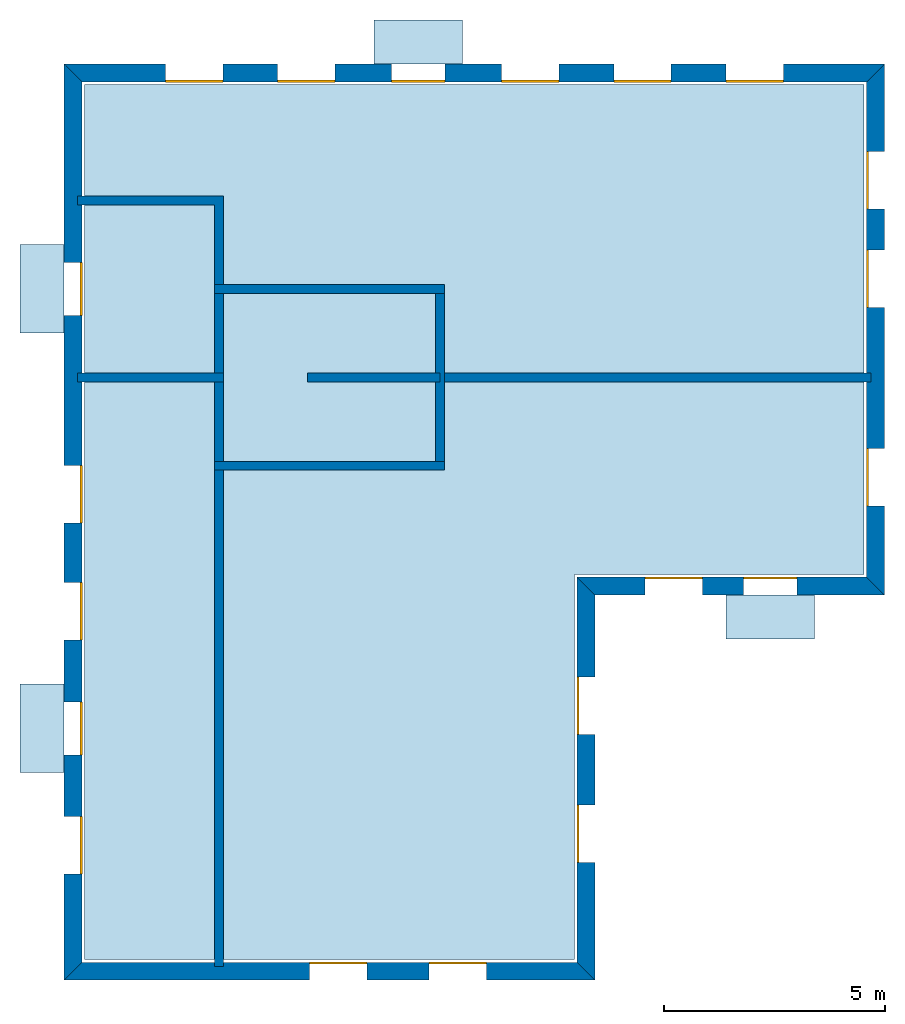
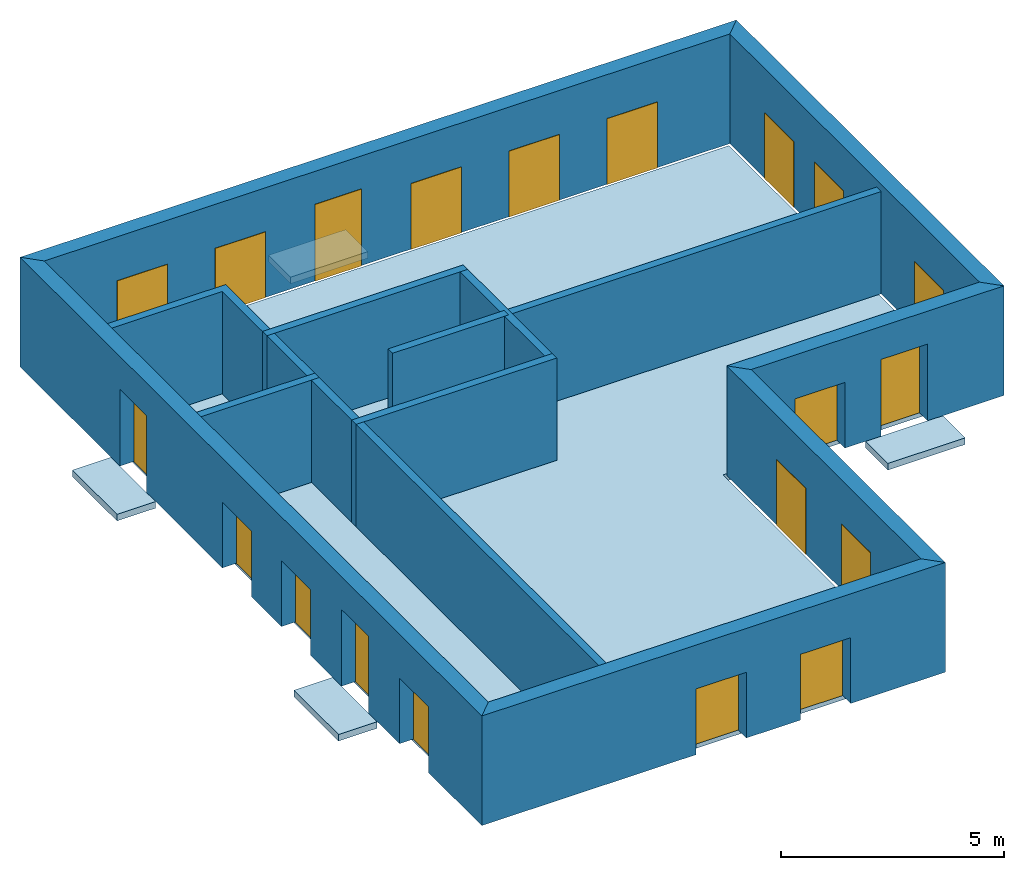
# One storey: 20 windows, 15 walls, 5 slabs, 20 openings.
"""IFC4 building model written with IfcOpenShell, lengths in metres."""

from ifc_helpers import new_model, si_unit, frame, origin_with_axes, place, context, subcontext, project, spatial, line, indexed_curve, outline, extrude, element, fill, save


model = new_model("IFC4")

# Units and contexts
model_context = context("Model", 3, precision=1e-05, world=origin_with_axes())
body_context = subcontext(model_context, "Body", "Model", "MODEL_VIEW")
ifc_project = project(units=[si_unit("AREAUNIT", "SQUARE_METRE"), si_unit("VOLUMEUNIT", "CUBIC_METRE"), si_unit("LENGTHUNIT", "METRE")], contexts=[model_context])

# Site, building, storey
site = spatial("IfcSite", under=ifc_project)
building = spatial("IfcBuilding", under=site, Name="Building 1")
storey_placement = place(None, frame((0.0, 0.0, 4.0), z_axis=(0.0, 0.0, 1.0), x_axis=(1.0, 0.0, 0.0)))
storey = spatial("IfcBuildingStorey", under=building, at=storey_placement, Name="02 Storey")

# Slabs
slab_1_placement = place(storey_placement, origin_with_axes())
element("IfcSlab", 1, at=slab_1_placement, inside=storey, Name="Slab", context=body_context, shape_type="SweptSolid", body=[
    extrude(outline(indexed_curve([(15.533354, 14.715575), (22.079464, 14.715575), (22.079464, 25.795575), (4.453354, 25.795575), (4.453354, 6.0082), (15.533354, 6.0082)], segments=[line(1, 2), line(2, 3), line(3, 4), line(4, 5), line(5, 6)])), origin_with_axes(), (0.0, 0.0, -1.0), 0.2),
])
slab_2_placement = place(storey_placement, origin_with_axes())
element("IfcSlab", 2, at=slab_2_placement, inside=storey, Name="Balcony", context=body_context, shape_type="SweptSolid", body=[
    extrude(outline(indexed_curve([(20.9574273333333, 14.255575), (20.9574273333333, 13.255575), (18.9574273333333, 13.255575), (18.9574273333333, 14.255575)], segments=[line(1, 2), line(2, 3), line(3, 4)])), origin_with_axes(), (0.0, 0.0, -1.0), 0.18),
])
slab_3_placement = place(storey_placement, origin_with_axes())
element("IfcSlab", 3, at=slab_3_placement, inside=storey, Name="Balcony", context=body_context, shape_type="SweptSolid", body=[
    extrude(outline(indexed_curve([(10.9988297142857, 26.255575), (10.9988297142857, 27.255575), (12.9988297142857, 27.255575), (12.9988297142857, 26.255575)], segments=[line(1, 2), line(2, 3), line(3, 4)])), origin_with_axes(), (0.0, 0.0, -1.0), 0.18),
])
slab_4_placement = place(storey_placement, origin_with_axes())
element("IfcSlab", 4, at=slab_4_placement, inside=storey, Name="Balcony", context=body_context, shape_type="SweptSolid", body=[
    extrude(outline(indexed_curve([(3.993354, 10.2388972), (2.993354, 10.2388972), (2.993354, 12.2388972), (3.993354, 12.2388972)], segments=[line(1, 2), line(2, 3), line(3, 4)])), origin_with_axes(), (0.0, 0.0, -1.0), 0.18),
])
slab_5_placement = place(storey_placement, origin_with_axes())
element("IfcSlab", 5, at=slab_5_placement, inside=storey, Name="Balcony", context=body_context, shape_type="SweptSolid", body=[
    extrude(outline(indexed_curve([(3.993354, 20.174943), (2.993354, 20.174943), (2.993354, 22.174943), (3.993354, 22.174943)], segments=[line(1, 2), line(2, 3), line(3, 4)])), origin_with_axes(), (0.0, 0.0, -1.0), 0.18),
])

# Walls
wall_1_placement = place(storey_placement, origin_with_axes())
element("IfcWall", 6, at=wall_1_placement, inside=storey, Name="Wall", context=body_context, shape_type="SweptSolid", body=[
    extrude(outline(indexed_curve([(22.239464, 19.274943), (12.393354, 19.274943), (12.393354, 19.074943), (22.239464, 19.074943)], segments=[line(1, 2), line(2, 3), line(3, 4)])), origin_with_axes(), (0.0, 0.0, 1.0), 2.8),
])
wall_2_placement = place(storey_placement, origin_with_axes())
element("IfcWall", 7, at=wall_2_placement, inside=storey, Name="Wall", context=body_context, shape_type="SweptSolid", body=[
    extrude(outline(indexed_curve([(7.593354, 17.274943), (7.393354, 17.274943), (7.393354, 5.8482), (7.593354, 5.8482)], segments=[line(1, 2), line(2, 3), line(3, 4)])), origin_with_axes(), (0.0, 0.0, 1.0), 2.8),
])
wall_3_placement = place(storey_placement, origin_with_axes())
element("IfcWall", 8, at=wall_3_placement, inside=storey, Name="Wall", context=body_context, shape_type="SweptSolid", body=[
    extrude(outline(indexed_curve([(7.593354, 19.274943), (4.293354, 19.274943), (4.293354, 19.074943), (7.593354, 19.074943)], segments=[line(1, 2), line(2, 3), line(3, 4)])), origin_with_axes(), (0.0, 0.0, 1.0), 2.8),
])
wall_4_placement = place(storey_placement, origin_with_axes())
element("IfcWall", 9, at=wall_4_placement, inside=storey, Name="Wall", context=body_context, shape_type="SweptSolid", body=[
    extrude(outline(indexed_curve([(7.593354, 23.274943), (4.293354, 23.274943), (4.293354, 23.074943), (7.393354, 23.074943), (7.393354, 21.074943), (7.593354, 21.074943)], segments=[line(1, 2), line(2, 3), line(3, 4), line(4, 5), line(5, 6)])), origin_with_axes(), (0.0, 0.0, 1.0), 2.8),
])

# Wall, openings, windows
wall_5_placement = place(storey_placement, origin_with_axes())
wall_5 = element("IfcWall", 10, at=wall_5_placement, inside=storey, Name="Facade", context=body_context, shape_type="SweptSolid", body=[
    extrude(outline(indexed_curve([(15.593354, 14.655575), (22.139464, 14.655575), (22.539464, 14.255575), (15.993354, 14.255575)], segments=[line(1, 2), line(2, 3), line(3, 4)])), origin_with_axes(), (0.0, 0.0, 1.0), 3.0),
])
opening_1_placement = place(wall_5_placement, origin_with_axes())
opening_1 = element("IfcOpeningElement", 11, at=opening_1_placement, cuts=wall_5, Name="Opening", context=body_context, shape_type="SweptSolid", body=[
    extrude(outline(indexed_curve([(17.1253906666667, 14.215575), (17.1253906666667, 14.715575), (18.4253906666667, 14.715575), (18.4253906666667, 14.215575)], segments=[line(1, 2), line(2, 3), line(3, 4)])), origin_with_axes(), (0.0, 0.0, 1.0), 1.8),
])
opening_2_placement = place(wall_5_placement, origin_with_axes())
opening_2 = element("IfcOpeningElement", 12, at=opening_2_placement, cuts=wall_5, Name="Opening", context=body_context, shape_type="SweptSolid", body=[
    extrude(outline(indexed_curve([(19.3574273333333, 14.215575), (19.3574273333333, 14.715575), (20.5574273333333, 14.715575), (20.5574273333333, 14.215575)], segments=[line(1, 2), line(2, 3), line(3, 4)])), origin_with_axes(), (0.0, 0.0, 1.0), 2.1),
])
window_1_placement = place(storey_placement, origin_with_axes())
window_1 = element("IfcWindow", 13, at=window_1_placement, inside=storey, Name="Window", PredefinedType="WINDOW", context=body_context, shape_type="SweptSolid", body=[
    extrude(outline(indexed_curve([(17.1253906666667, 14.615575), (17.1253906666667, 14.665575), (18.4253906666667, 14.665575), (18.4253906666667, 14.615575)], segments=[line(1, 2), line(2, 3), line(3, 4)])), origin_with_axes(), (0.0, 0.0, 1.0), 1.8),
])
fill(opening_1, window_1)
window_2_placement = place(storey_placement, origin_with_axes())
window_2 = element("IfcWindow", 14, at=window_2_placement, inside=storey, Name="Window", PredefinedType="WINDOW", context=body_context, shape_type="SweptSolid", body=[
    extrude(outline(indexed_curve([(19.3574273333333, 14.615575), (19.3574273333333, 14.665575), (20.5574273333333, 14.665575), (20.5574273333333, 14.615575)], segments=[line(1, 2), line(2, 3), line(3, 4)])), origin_with_axes(), (0.0, 0.0, 1.0), 2.1),
])
fill(opening_2, window_2)

wall_6_placement = place(storey_placement, origin_with_axes())
wall_6 = element("IfcWall", 15, at=wall_6_placement, inside=storey, Name="Facade", context=body_context, shape_type="SweptSolid", body=[
    extrude(outline(indexed_curve([(22.139464, 14.655575), (22.139464, 25.855575), (22.539464, 26.255575), (22.539464, 14.255575)], segments=[line(1, 2), line(2, 3), line(3, 4)])), origin_with_axes(), (0.0, 0.0, 1.0), 3.0),
])
opening_3_placement = place(wall_6_placement, origin_with_axes())
opening_3 = element("IfcOpeningElement", 16, at=opening_3_placement, cuts=wall_6, Name="Opening", context=body_context, shape_type="SweptSolid", body=[
    extrude(outline(indexed_curve([(22.579464, 16.265259), (22.079464, 16.265259), (22.079464, 17.565259), (22.579464, 17.565259)], segments=[line(1, 2), line(2, 3), line(3, 4)])), origin_with_axes(), (0.0, 0.0, 1.0), 1.8),
])
opening_4_placement = place(wall_6_placement, origin_with_axes())
opening_4 = element("IfcOpeningElement", 17, at=opening_4_placement, cuts=wall_6, Name="Opening", context=body_context, shape_type="SweptSolid", body=[
    extrude(outline(indexed_curve([(22.579464, 20.7518203333333), (22.079464, 20.7518203333333), (22.079464, 22.0518203333333), (22.579464, 22.0518203333333)], segments=[line(1, 2), line(2, 3), line(3, 4)])), origin_with_axes(), (0.0, 0.0, 1.0), 1.8),
])
opening_5_placement = place(wall_6_placement, origin_with_axes())
opening_5 = element("IfcOpeningElement", 18, at=opening_5_placement, cuts=wall_6, Name="Opening", context=body_context, shape_type="SweptSolid", body=[
    extrude(outline(indexed_curve([(22.579464, 22.9786976666667), (22.079464, 22.9786976666667), (22.079464, 24.2786976666667), (22.579464, 24.2786976666667)], segments=[line(1, 2), line(2, 3), line(3, 4)])), origin_with_axes(), (0.0, 0.0, 1.0), 1.8),
])
window_3_placement = place(storey_placement, origin_with_axes())
window_3 = element("IfcWindow", 19, at=window_3_placement, inside=storey, Name="Window", PredefinedType="WINDOW", context=body_context, shape_type="SweptSolid", body=[
    extrude(outline(indexed_curve([(22.179464, 16.265259), (22.129464, 16.265259), (22.129464, 17.565259), (22.179464, 17.565259)], segments=[line(1, 2), line(2, 3), line(3, 4)])), origin_with_axes(), (0.0, 0.0, 1.0), 1.8),
])
fill(opening_3, window_3)
window_4_placement = place(storey_placement, origin_with_axes())
window_4 = element("IfcWindow", 20, at=window_4_placement, inside=storey, Name="Window", PredefinedType="WINDOW", context=body_context, shape_type="SweptSolid", body=[
    extrude(outline(indexed_curve([(22.179464, 20.7518203333333), (22.129464, 20.7518203333333), (22.129464, 22.0518203333333), (22.179464, 22.0518203333333)], segments=[line(1, 2), line(2, 3), line(3, 4)])), origin_with_axes(), (0.0, 0.0, 1.0), 1.8),
])
fill(opening_4, window_4)
window_5_placement = place(storey_placement, origin_with_axes())
window_5 = element("IfcWindow", 21, at=window_5_placement, inside=storey, Name="Window", PredefinedType="WINDOW", context=body_context, shape_type="SweptSolid", body=[
    extrude(outline(indexed_curve([(22.179464, 22.9786976666667), (22.129464, 22.9786976666667), (22.129464, 24.2786976666667), (22.179464, 24.2786976666667)], segments=[line(1, 2), line(2, 3), line(3, 4)])), origin_with_axes(), (0.0, 0.0, 1.0), 1.8),
])
fill(opening_5, window_5)

wall_7_placement = place(storey_placement, origin_with_axes())
wall_7 = element("IfcWall", 22, at=wall_7_placement, inside=storey, Name="Facade", context=body_context, shape_type="SweptSolid", body=[
    extrude(outline(indexed_curve([(22.139464, 25.855575), (4.393354, 25.855575), (3.993354, 26.255575), (22.539464, 26.255575)], segments=[line(1, 2), line(2, 3), line(3, 4)])), origin_with_axes(), (0.0, 0.0, 1.0), 3.0),
])
opening_6_placement = place(wall_7_placement, origin_with_axes())
opening_6 = element("IfcOpeningElement", 23, at=opening_6_placement, cuts=wall_7, Name="Opening", context=body_context, shape_type="SweptSolid", body=[
    extrude(outline(indexed_curve([(20.2543054285714, 26.295575), (20.2543054285714, 25.795575), (18.9543054285714, 25.795575), (18.9543054285714, 26.295575)], segments=[line(1, 2), line(2, 3), line(3, 4)])), origin_with_axes(), (0.0, 0.0, 1.0), 1.8),
])
opening_7_placement = place(wall_7_placement, origin_with_axes())
opening_7 = element("IfcOpeningElement", 24, at=opening_7_placement, cuts=wall_7, Name="Opening", context=body_context, shape_type="SweptSolid", body=[
    extrude(outline(indexed_curve([(17.7191468571429, 26.295575), (17.7191468571429, 25.795575), (16.4191468571429, 25.795575), (16.4191468571429, 26.295575)], segments=[line(1, 2), line(2, 3), line(3, 4)])), origin_with_axes(), (0.0, 0.0, 1.0), 1.8),
])
opening_8_placement = place(wall_7_placement, origin_with_axes())
opening_8 = element("IfcOpeningElement", 25, at=opening_8_placement, cuts=wall_7, Name="Opening", context=body_context, shape_type="SweptSolid", body=[
    extrude(outline(indexed_curve([(15.1839882857143, 26.295575), (15.1839882857143, 25.795575), (13.8839882857143, 25.795575), (13.8839882857143, 26.295575)], segments=[line(1, 2), line(2, 3), line(3, 4)])), origin_with_axes(), (0.0, 0.0, 1.0), 1.8),
])
opening_9_placement = place(wall_7_placement, origin_with_axes())
opening_9 = element("IfcOpeningElement", 26, at=opening_9_placement, cuts=wall_7, Name="Opening", context=body_context, shape_type="SweptSolid", body=[
    extrude(outline(indexed_curve([(12.5988297142857, 26.295575), (12.5988297142857, 25.795575), (11.3988297142857, 25.795575), (11.3988297142857, 26.295575)], segments=[line(1, 2), line(2, 3), line(3, 4)])), origin_with_axes(), (0.0, 0.0, 1.0), 2.1),
])
opening_10_placement = place(wall_7_placement, origin_with_axes())
opening_10 = element("IfcOpeningElement", 27, at=opening_10_placement, cuts=wall_7, Name="Opening", context=body_context, shape_type="SweptSolid", body=[
    extrude(outline(indexed_curve([(10.1136711428571, 26.295575), (10.1136711428571, 25.795575), (8.81367114285714, 25.795575), (8.81367114285714, 26.295575)], segments=[line(1, 2), line(2, 3), line(3, 4)])), origin_with_axes(), (0.0, 0.0, 1.0), 1.8),
])
opening_11_placement = place(wall_7_placement, origin_with_axes())
opening_11 = element("IfcOpeningElement", 28, at=opening_11_placement, cuts=wall_7, Name="Opening", context=body_context, shape_type="SweptSolid", body=[
    extrude(outline(indexed_curve([(7.57851257142857, 26.295575), (7.57851257142857, 25.795575), (6.27851257142857, 25.795575), (6.27851257142857, 26.295575)], segments=[line(1, 2), line(2, 3), line(3, 4)])), origin_with_axes(), (0.0, 0.0, 1.0), 1.8),
])
window_6_placement = place(storey_placement, origin_with_axes())
window_6 = element("IfcWindow", 29, at=window_6_placement, inside=storey, Name="Window", PredefinedType="WINDOW", context=body_context, shape_type="SweptSolid", body=[
    extrude(outline(indexed_curve([(20.2543054285714, 25.895575), (20.2543054285714, 25.845575), (18.9543054285714, 25.845575), (18.9543054285714, 25.895575)], segments=[line(1, 2), line(2, 3), line(3, 4)])), origin_with_axes(), (0.0, 0.0, 1.0), 1.8),
])
fill(opening_6, window_6)
window_7_placement = place(storey_placement, origin_with_axes())
window_7 = element("IfcWindow", 30, at=window_7_placement, inside=storey, Name="Window", PredefinedType="WINDOW", context=body_context, shape_type="SweptSolid", body=[
    extrude(outline(indexed_curve([(17.7191468571429, 25.895575), (17.7191468571429, 25.845575), (16.4191468571429, 25.845575), (16.4191468571429, 25.895575)], segments=[line(1, 2), line(2, 3), line(3, 4)])), origin_with_axes(), (0.0, 0.0, 1.0), 1.8),
])
fill(opening_7, window_7)
window_8_placement = place(storey_placement, origin_with_axes())
window_8 = element("IfcWindow", 31, at=window_8_placement, inside=storey, Name="Window", PredefinedType="WINDOW", context=body_context, shape_type="SweptSolid", body=[
    extrude(outline(indexed_curve([(15.1839882857143, 25.895575), (15.1839882857143, 25.845575), (13.8839882857143, 25.845575), (13.8839882857143, 25.895575)], segments=[line(1, 2), line(2, 3), line(3, 4)])), origin_with_axes(), (0.0, 0.0, 1.0), 1.8),
])
fill(opening_8, window_8)
window_9_placement = place(storey_placement, origin_with_axes())
window_9 = element("IfcWindow", 32, at=window_9_placement, inside=storey, Name="Window", PredefinedType="WINDOW", context=body_context, shape_type="SweptSolid", body=[
    extrude(outline(indexed_curve([(12.5988297142857, 25.895575), (12.5988297142857, 25.845575), (11.3988297142857, 25.845575), (11.3988297142857, 25.895575)], segments=[line(1, 2), line(2, 3), line(3, 4)])), origin_with_axes(), (0.0, 0.0, 1.0), 2.1),
])
fill(opening_9, window_9)
window_10_placement = place(storey_placement, origin_with_axes())
window_10 = element("IfcWindow", 33, at=window_10_placement, inside=storey, Name="Window", PredefinedType="WINDOW", context=body_context, shape_type="SweptSolid", body=[
    extrude(outline(indexed_curve([(10.1136711428571, 25.895575), (10.1136711428571, 25.845575), (8.81367114285714, 25.845575), (8.81367114285714, 25.895575)], segments=[line(1, 2), line(2, 3), line(3, 4)])), origin_with_axes(), (0.0, 0.0, 1.0), 1.8),
])
fill(opening_10, window_10)
window_11_placement = place(storey_placement, origin_with_axes())
window_11 = element("IfcWindow", 34, at=window_11_placement, inside=storey, Name="Window", PredefinedType="WINDOW", context=body_context, shape_type="SweptSolid", body=[
    extrude(outline(indexed_curve([(7.57851257142857, 25.895575), (7.57851257142857, 25.845575), (6.27851257142857, 25.845575), (6.27851257142857, 25.895575)], segments=[line(1, 2), line(2, 3), line(3, 4)])), origin_with_axes(), (0.0, 0.0, 1.0), 1.8),
])
fill(opening_11, window_11)

wall_8_placement = place(storey_placement, origin_with_axes())
wall_8 = element("IfcWall", 35, at=wall_8_placement, inside=storey, Name="Facade", context=body_context, shape_type="SweptSolid", body=[
    extrude(outline(indexed_curve([(4.393354, 25.855575), (4.393354, 5.9482), (3.993354, 5.5482), (3.993354, 26.255575)], segments=[line(1, 2), line(2, 3), line(3, 4)])), origin_with_axes(), (0.0, 0.0, 1.0), 3.0),
])
opening_12_placement = place(wall_8_placement, origin_with_axes())
opening_12 = element("IfcOpeningElement", 36, at=opening_12_placement, cuts=wall_8, Name="Opening", context=body_context, shape_type="SweptSolid", body=[
    extrude(outline(indexed_curve([(3.953354, 17.1795944), (4.453354, 17.1795944), (4.453354, 15.8795944), (3.953354, 15.8795944)], segments=[line(1, 2), line(2, 3), line(3, 4)])), origin_with_axes(), (0.0, 0.0, 1.0), 1.8),
])
opening_13_placement = place(wall_8_placement, origin_with_axes())
opening_13 = element("IfcOpeningElement", 37, at=opening_13_placement, cuts=wall_8, Name="Opening", context=body_context, shape_type="SweptSolid", body=[
    extrude(outline(indexed_curve([(3.953354, 14.5342458), (4.453354, 14.5342458), (4.453354, 13.2342458), (3.953354, 13.2342458)], segments=[line(1, 2), line(2, 3), line(3, 4)])), origin_with_axes(), (0.0, 0.0, 1.0), 1.8),
])
opening_14_placement = place(wall_8_placement, origin_with_axes())
opening_14 = element("IfcOpeningElement", 38, at=opening_14_placement, cuts=wall_8, Name="Opening", context=body_context, shape_type="SweptSolid", body=[
    extrude(outline(indexed_curve([(3.953354, 11.8388972), (4.453354, 11.8388972), (4.453354, 10.6388972), (3.953354, 10.6388972)], segments=[line(1, 2), line(2, 3), line(3, 4)])), origin_with_axes(), (0.0, 0.0, 1.0), 2.1),
])
opening_15_placement = place(wall_8_placement, origin_with_axes())
opening_15 = element("IfcOpeningElement", 39, at=opening_15_placement, cuts=wall_8, Name="Opening", context=body_context, shape_type="SweptSolid", body=[
    extrude(outline(indexed_curve([(3.953354, 9.2435486), (4.453354, 9.2435486), (4.453354, 7.9435486), (3.953354, 7.9435486)], segments=[line(1, 2), line(2, 3), line(3, 4)])), origin_with_axes(), (0.0, 0.0, 1.0), 1.8),
])
opening_16_placement = place(wall_8_placement, origin_with_axes())
opening_16 = element("IfcOpeningElement", 40, at=opening_16_placement, cuts=wall_8, Name="Opening", context=body_context, shape_type="SweptSolid", body=[
    extrude(outline(indexed_curve([(3.953354, 21.774943), (4.453354, 21.774943), (4.453354, 20.574943), (3.953354, 20.574943)], segments=[line(1, 2), line(2, 3), line(3, 4)])), origin_with_axes(), (0.0, 0.0, 1.0), 2.1),
])
window_12_placement = place(storey_placement, origin_with_axes())
window_12 = element("IfcWindow", 41, at=window_12_placement, inside=storey, Name="Window", PredefinedType="WINDOW", context=body_context, shape_type="SweptSolid", body=[
    extrude(outline(indexed_curve([(4.353354, 17.1795944), (4.403354, 17.1795944), (4.403354, 15.8795944), (4.353354, 15.8795944)], segments=[line(1, 2), line(2, 3), line(3, 4)])), origin_with_axes(), (0.0, 0.0, 1.0), 1.8),
])
fill(opening_12, window_12)
window_13_placement = place(storey_placement, origin_with_axes())
window_13 = element("IfcWindow", 42, at=window_13_placement, inside=storey, Name="Window", PredefinedType="WINDOW", context=body_context, shape_type="SweptSolid", body=[
    extrude(outline(indexed_curve([(4.353354, 14.5342458), (4.403354, 14.5342458), (4.403354, 13.2342458), (4.353354, 13.2342458)], segments=[line(1, 2), line(2, 3), line(3, 4)])), origin_with_axes(), (0.0, 0.0, 1.0), 1.8),
])
fill(opening_13, window_13)
window_14_placement = place(storey_placement, origin_with_axes())
window_14 = element("IfcWindow", 43, at=window_14_placement, inside=storey, Name="Window", PredefinedType="WINDOW", context=body_context, shape_type="SweptSolid", body=[
    extrude(outline(indexed_curve([(4.353354, 11.8388972), (4.403354, 11.8388972), (4.403354, 10.6388972), (4.353354, 10.6388972)], segments=[line(1, 2), line(2, 3), line(3, 4)])), origin_with_axes(), (0.0, 0.0, 1.0), 2.1),
])
fill(opening_14, window_14)
window_15_placement = place(storey_placement, origin_with_axes())
window_15 = element("IfcWindow", 44, at=window_15_placement, inside=storey, Name="Window", PredefinedType="WINDOW", context=body_context, shape_type="SweptSolid", body=[
    extrude(outline(indexed_curve([(4.353354, 9.2435486), (4.403354, 9.2435486), (4.403354, 7.9435486), (4.353354, 7.9435486)], segments=[line(1, 2), line(2, 3), line(3, 4)])), origin_with_axes(), (0.0, 0.0, 1.0), 1.8),
])
fill(opening_15, window_15)
window_16_placement = place(storey_placement, origin_with_axes())
window_16 = element("IfcWindow", 45, at=window_16_placement, inside=storey, Name="Window", PredefinedType="WINDOW", context=body_context, shape_type="SweptSolid", body=[
    extrude(outline(indexed_curve([(4.353354, 21.774943), (4.403354, 21.774943), (4.403354, 20.574943), (4.353354, 20.574943)], segments=[line(1, 2), line(2, 3), line(3, 4)])), origin_with_axes(), (0.0, 0.0, 1.0), 2.1),
])
fill(opening_16, window_16)

wall_9_placement = place(storey_placement, origin_with_axes())
wall_9 = element("IfcWall", 46, at=wall_9_placement, inside=storey, Name="Facade", context=body_context, shape_type="SweptSolid", body=[
    extrude(outline(indexed_curve([(4.393354, 5.9482), (15.593354, 5.9482), (15.993354, 5.5482), (3.993354, 5.5482)], segments=[line(1, 2), line(2, 3), line(3, 4)])), origin_with_axes(), (0.0, 0.0, 1.0), 3.0),
])
opening_17_placement = place(wall_9_placement, origin_with_axes())
opening_17 = element("IfcOpeningElement", 47, at=opening_17_placement, cuts=wall_9, Name="Opening", context=body_context, shape_type="SweptSolid", body=[
    extrude(outline(indexed_curve([(9.543354, 5.5082), (9.543354, 6.0082), (10.843354, 6.0082), (10.843354, 5.5082)], segments=[line(1, 2), line(2, 3), line(3, 4)])), origin_with_axes(), (0.0, 0.0, 1.0), 1.8),
])
opening_18_placement = place(wall_9_placement, origin_with_axes())
opening_18 = element("IfcOpeningElement", 48, at=opening_18_placement, cuts=wall_9, Name="Opening", context=body_context, shape_type="SweptSolid", body=[
    extrude(outline(indexed_curve([(12.243354, 5.5082), (12.243354, 6.0082), (13.543354, 6.0082), (13.543354, 5.5082)], segments=[line(1, 2), line(2, 3), line(3, 4)])), origin_with_axes(), (0.0, 0.0, 1.0), 1.8),
])
window_17_placement = place(storey_placement, origin_with_axes())
window_17 = element("IfcWindow", 49, at=window_17_placement, inside=storey, Name="Window", PredefinedType="WINDOW", context=body_context, shape_type="SweptSolid", body=[
    extrude(outline(indexed_curve([(9.543354, 5.9082), (9.543354, 5.9582), (10.843354, 5.9582), (10.843354, 5.9082)], segments=[line(1, 2), line(2, 3), line(3, 4)])), origin_with_axes(), (0.0, 0.0, 1.0), 1.8),
])
fill(opening_17, window_17)
window_18_placement = place(storey_placement, origin_with_axes())
window_18 = element("IfcWindow", 50, at=window_18_placement, inside=storey, Name="Window", PredefinedType="WINDOW", context=body_context, shape_type="SweptSolid", body=[
    extrude(outline(indexed_curve([(12.243354, 5.9082), (12.243354, 5.9582), (13.543354, 5.9582), (13.543354, 5.9082)], segments=[line(1, 2), line(2, 3), line(3, 4)])), origin_with_axes(), (0.0, 0.0, 1.0), 1.8),
])
fill(opening_18, window_18)

wall_10_placement = place(storey_placement, origin_with_axes())
wall_10 = element("IfcWall", 51, at=wall_10_placement, inside=storey, Name="Facade", context=body_context, shape_type="SweptSolid", body=[
    extrude(outline(indexed_curve([(15.593354, 5.9482), (15.593354, 14.655575), (15.993354, 14.255575), (15.993354, 5.5482)], segments=[line(1, 2), line(2, 3), line(3, 4)])), origin_with_axes(), (0.0, 0.0, 1.0), 3.0),
])
opening_19_placement = place(wall_10_placement, origin_with_axes())
opening_19 = element("IfcOpeningElement", 52, at=opening_19_placement, cuts=wall_10, Name="Opening", context=body_context, shape_type="SweptSolid", body=[
    extrude(outline(indexed_curve([(16.033354, 8.20065833333333), (15.533354, 8.20065833333333), (15.533354, 9.50065833333333), (16.033354, 9.50065833333333)], segments=[line(1, 2), line(2, 3), line(3, 4)])), origin_with_axes(), (0.0, 0.0, 1.0), 1.8),
])
opening_20_placement = place(wall_10_placement, origin_with_axes())
opening_20 = element("IfcOpeningElement", 53, at=opening_20_placement, cuts=wall_10, Name="Opening", context=body_context, shape_type="SweptSolid", body=[
    extrude(outline(indexed_curve([(16.033354, 11.1031166666667), (15.533354, 11.1031166666667), (15.533354, 12.4031166666667), (16.033354, 12.4031166666667)], segments=[line(1, 2), line(2, 3), line(3, 4)])), origin_with_axes(), (0.0, 0.0, 1.0), 1.8),
])
window_19_placement = place(storey_placement, origin_with_axes())
window_19 = element("IfcWindow", 54, at=window_19_placement, inside=storey, Name="Window", PredefinedType="WINDOW", context=body_context, shape_type="SweptSolid", body=[
    extrude(outline(indexed_curve([(15.633354, 8.20065833333333), (15.583354, 8.20065833333333), (15.583354, 9.50065833333333), (15.633354, 9.50065833333333)], segments=[line(1, 2), line(2, 3), line(3, 4)])), origin_with_axes(), (0.0, 0.0, 1.0), 1.8),
])
fill(opening_19, window_19)
window_20_placement = place(storey_placement, origin_with_axes())
window_20 = element("IfcWindow", 55, at=window_20_placement, inside=storey, Name="Window", PredefinedType="WINDOW", context=body_context, shape_type="SweptSolid", body=[
    extrude(outline(indexed_curve([(15.633354, 11.1031166666667), (15.583354, 11.1031166666667), (15.583354, 12.4031166666667), (15.633354, 12.4031166666667)], segments=[line(1, 2), line(2, 3), line(3, 4)])), origin_with_axes(), (0.0, 0.0, 1.0), 1.8),
])
fill(opening_20, window_20)

# Walls
wall_11_placement = place(storey_placement, origin_with_axes())
element("IfcWall", 56, at=wall_11_placement, inside=storey, Name="CoreWall", context=body_context, shape_type="SweptSolid", body=[
    extrude(outline(indexed_curve([(12.593354, 21.274943), (7.393354, 21.274943), (7.393354, 21.074943), (12.593354, 21.074943)], segments=[line(1, 2), line(2, 3), line(3, 4)])), origin_with_axes(), (0.0, 0.0, 1.0), 2.8),
])
wall_12_placement = place(storey_placement, origin_with_axes())
element("IfcWall", 57, at=wall_12_placement, inside=storey, Name="CoreWall", context=body_context, shape_type="SweptSolid", body=[
    extrude(outline(indexed_curve([(7.393354, 17.074943), (12.593354, 17.074943), (12.593354, 17.274943), (7.393354, 17.274943)], segments=[line(1, 2), line(2, 3), line(3, 4)])), origin_with_axes(), (0.0, 0.0, 1.0), 2.8),
])
wall_13_placement = place(storey_placement, origin_with_axes())
element("IfcWall", 58, at=wall_13_placement, inside=storey, Name="CoreWall", context=body_context, shape_type="SweptSolid", body=[
    extrude(outline(indexed_curve([(7.593354, 17.274943), (7.593354, 21.074943), (7.393354, 21.074943), (7.393354, 17.274943)], segments=[line(1, 2), line(2, 3), line(3, 4)])), origin_with_axes(), (0.0, 0.0, 1.0), 2.8),
])
wall_14_placement = place(storey_placement, origin_with_axes())
element("IfcWall", 59, at=wall_14_placement, inside=storey, Name="CoreWall", context=body_context, shape_type="SweptSolid", body=[
    extrude(outline(indexed_curve([(12.393354, 21.074943), (12.393354, 17.274943), (12.593354, 17.274943), (12.593354, 21.074943)], segments=[line(1, 2), line(2, 3), line(3, 4)])), origin_with_axes(), (0.0, 0.0, 1.0), 2.8),
])
wall_15_placement = place(storey_placement, origin_with_axes())
element("IfcWall", 60, at=wall_15_placement, inside=storey, Name="CoreWall", context=body_context, shape_type="SweptSolid", body=[
    extrude(outline(indexed_curve([(12.493354, 19.274943), (9.493354, 19.274943), (9.493354, 19.074943), (12.493354, 19.074943)], segments=[line(1, 2), line(2, 3), line(3, 4)])), origin_with_axes(), (0.0, 0.0, 1.0), 2.8),
])

save(model, "model.ifc")
